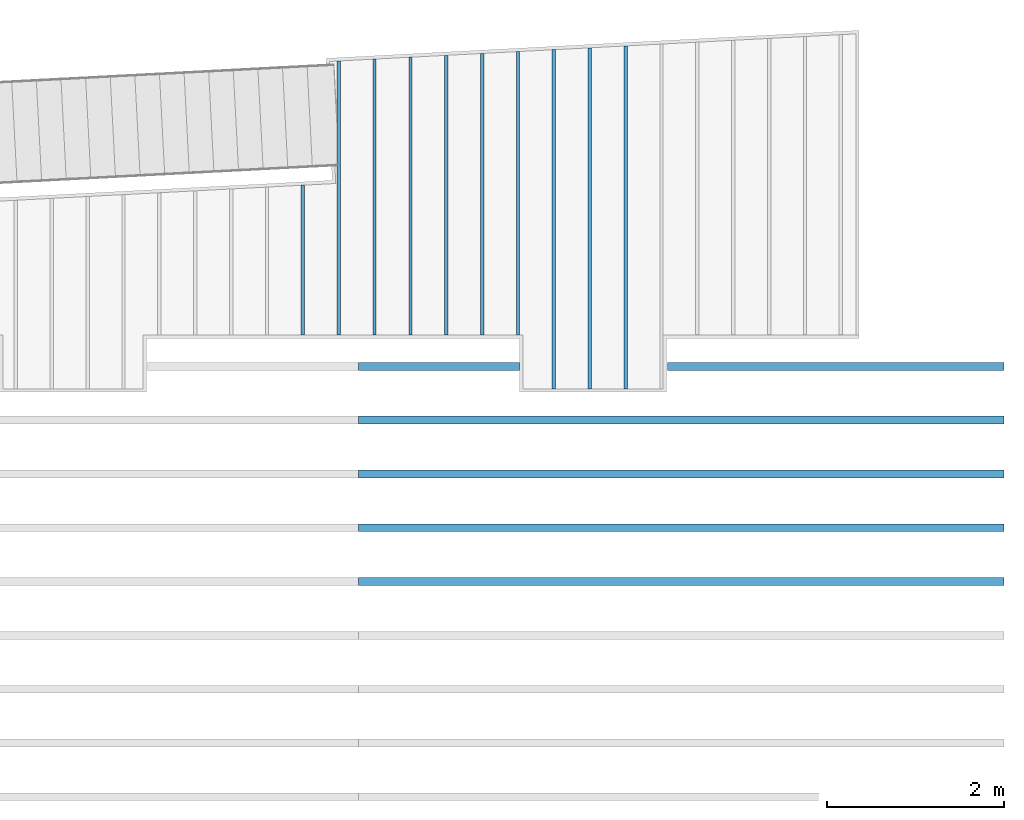
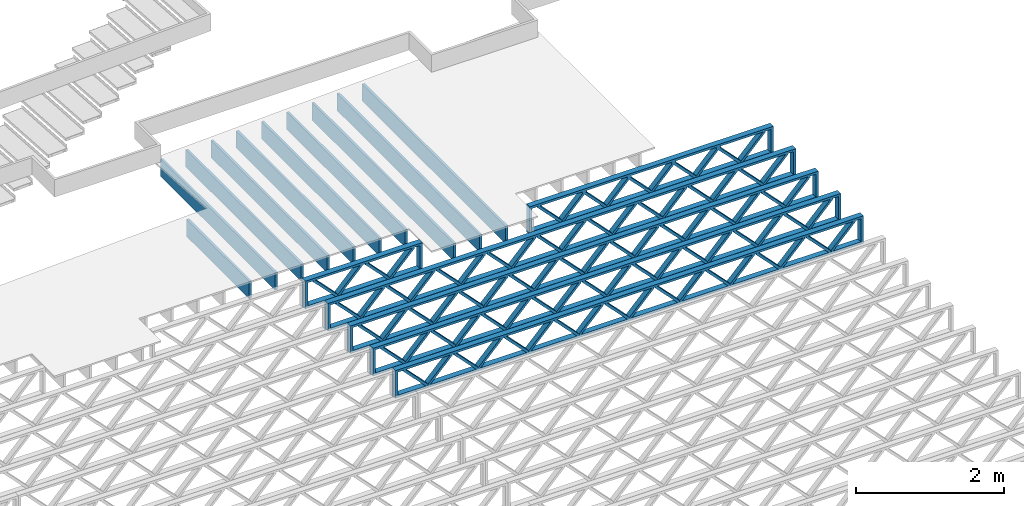
# One storey, part 12 of 23: 16 beams, 2 elements without a shape of their own.
"""IFC4 building model written with IfcOpenShell, lengths in feet."""

from ifc_helpers import new_model, entity, si_unit, converted_unit, derived_unit, direction, frame, frame_2d, origin, origin_2d_with_axis, place, context, subcontext, project, spatial, rectangle, extrude, source, transform, mapped, material, material_profile, profile_set, profile_usage, type_object, type_shapes, element, aggregate, save


model = new_model("IFC4")

# Units and contexts
model_context_1 = context("Model", 3, precision=0.0001, world=origin(), true_north=direction((6.12303176911189e-17, 1.0)))
model_context_2 = context("Model", 3, precision=0.0001, world=origin(), true_north=direction((6.12303176911189e-17, 1.0)))
body_context = subcontext(model_context_2, "Body", "Model", "MODEL_VIEW")
ifc_project = project(units=[converted_unit("LENGTHUNIT", "FOOT", entity("IfcRatioMeasure", 0.3048), si_unit("LENGTHUNIT", "METRE"), dimensions=[1, 0, 0, 0, 0, 0, 0]), converted_unit("AREAUNIT", "SQUARE FOOT", entity("IfcRatioMeasure", 0.09290304), si_unit("AREAUNIT", "SQUARE_METRE"), dimensions=[2, 0, 0, 0, 0, 0, 0]), converted_unit("VOLUMEUNIT", "CUBIC FOOT", entity("IfcRatioMeasure", 0.028316846592), si_unit("VOLUMEUNIT", "CUBIC_METRE"), dimensions=[3, 0, 0, 0, 0, 0, 0]), converted_unit("PLANEANGLEUNIT", "DEGREE", entity("IfcRatioMeasure", 0.0174532925199433), si_unit("PLANEANGLEUNIT", "RADIAN"), dimensions=[0, 0, 0, 0, 0, 0, 0]), si_unit("MASSUNIT", "GRAM", prefix="KILO"), derived_unit("MASSDENSITYUNIT", [(si_unit("MASSUNIT", "GRAM", prefix="KILO"), 1), (si_unit("LENGTHUNIT", "METRE"), -3)]), derived_unit("MOMENTOFINERTIAUNIT", [(si_unit("LENGTHUNIT", "METRE"), 4)]), si_unit("TIMEUNIT", "SECOND"), si_unit("FREQUENCYUNIT", "HERTZ"), si_unit("THERMODYNAMICTEMPERATUREUNIT", "DEGREE_CELSIUS"), derived_unit("THERMALTRANSMITTANCEUNIT", [(si_unit("MASSUNIT", "GRAM", prefix="KILO"), 1), (si_unit("THERMODYNAMICTEMPERATUREUNIT", "KELVIN"), -1), (si_unit("TIMEUNIT", "SECOND"), -3)]), derived_unit("VOLUMETRICFLOWRATEUNIT", [(si_unit("LENGTHUNIT", "METRE"), 3), (si_unit("TIMEUNIT", "SECOND"), -1)]), si_unit("ELECTRICCURRENTUNIT", "AMPERE"), si_unit("ELECTRICVOLTAGEUNIT", "VOLT"), si_unit("POWERUNIT", "WATT"), si_unit("FORCEUNIT", "NEWTON"), si_unit("ILLUMINANCEUNIT", "LUX"), si_unit("LUMINOUSFLUXUNIT", "LUMEN"), si_unit("LUMINOUSINTENSITYUNIT", "CANDELA"), derived_unit("USERDEFINED", [(si_unit("MASSUNIT", "GRAM", prefix="KILO"), -1), (si_unit("LENGTHUNIT", "METRE"), -2), (si_unit("TIMEUNIT", "SECOND"), 3), (si_unit("LUMINOUSFLUXUNIT", "LUMEN"), 1)]), derived_unit("LINEARVELOCITYUNIT", [(si_unit("LENGTHUNIT", "METRE"), 1), (si_unit("TIMEUNIT", "SECOND"), -1)]), si_unit("PRESSUREUNIT", "PASCAL"), derived_unit("USERDEFINED", [(si_unit("LENGTHUNIT", "METRE"), -2), (si_unit("MASSUNIT", "GRAM", prefix="KILO"), 1), (si_unit("TIMEUNIT", "SECOND"), -2)]), derived_unit("LINEARFORCEUNIT", [(si_unit("MASSUNIT", "GRAM", prefix="KILO"), 1), (si_unit("LENGTHUNIT", "METRE"), 1), (si_unit("TIMEUNIT", "SECOND"), -2), (si_unit("LENGTHUNIT", "METRE"), -1)]), derived_unit("PLANARFORCEUNIT", [(si_unit("MASSUNIT", "GRAM", prefix="KILO"), 1), (si_unit("LENGTHUNIT", "METRE"), 1), (si_unit("TIMEUNIT", "SECOND"), -2), (si_unit("LENGTHUNIT", "METRE"), -2)])], contexts=[model_context_1])

# Site, building, storey
site_placement = place(None, origin())
site = spatial("IfcSite", under=ifc_project, at=site_placement, CompositionType="ELEMENT")
building_placement = place(site_placement, origin())
building = spatial("IfcBuilding", under=site, at=building_placement, CompositionType="ELEMENT")
storey_placement = place(building_placement, frame((0.0, 0.0, 10.8020833333333)))
storey = spatial("IfcBuildingStorey", under=building, at=storey_placement, Name="2ND FLOOR", CompositionType="ELEMENT", Elevation=10.8020833333333)

# Assembly, beams
assembly_1_placement = place(storey_placement, origin())
assembly_1 = element("IfcElementAssembly", 1, at=assembly_1_placement, inside=storey, Name="Structural Beam System:Structural Framing System", ObjectType="Structural Beam System:Structural Framing System", AssemblyPlace="NOTDEFINED", PredefinedType="BEAM_GRID")
ifc_material_1 = material(Category="Materials")
ifc_material_profile_1 = material_profile(ifc_material_1, rectangle(XDim=0.9375, YDim=0.125000000000011, at=origin_2d_with_axis()))
ifc_profile_set_1 = profile_set([ifc_material_profile_1])
ifc_profile_usage_1 = profile_usage(ifc_profile_set_1, cardinal=8)
beam_type_1 = type_object("IfcBeamType", PredefinedType="BEAM", material=ifc_profile_set_1)
shared_shape_1 = source(origin(), body_context, "Body", "SweptSolid", [
    extrude(rectangle(XDim=0.9375, YDim=0.125000000000011, at=origin_2d_with_axis()), frame((-6.33615206190325, 0.0, 0.0), z_axis=(1.0, 0.0, 0.0), x_axis=(0.0, 0.0, -1.0)), (0.0, 0.0, 1.0), 12.6723041238065),
])
type_shapes(beam_type_1, [shared_shape_1])
beam_1_placement = place(assembly_1_placement, frame((-155.800660485462, 963.364753611221, -0.729166666666744), z_axis=(0.0, 0.0, 1.0), x_axis=(0.0, 1.0, 0.0)))
beam_1 = element("IfcBeam", 2, at=beam_1_placement, type_object=beam_type_1, material=ifc_profile_usage_1, PredefinedType="BEAM", context=body_context, shape_type="MappedRepresentation", body=[
    mapped(shared_shape_1, transform((0.0, 0.0, 0.0), scale=1.0)),
])
ifc_profile_usage_2 = profile_usage(ifc_profile_set_1, cardinal=8)
beam_type_2 = type_object("IfcBeamType", PredefinedType="BEAM", material=ifc_profile_set_1)
shared_shape_2 = source(origin(), body_context, "Body", "SweptSolid", [
    extrude(rectangle(XDim=0.9375, YDim=0.125000000000011, at=origin_2d_with_axis()), frame((-6.30121354238122, 0.0, 0.0), z_axis=(1.0, 0.0, 0.0), x_axis=(0.0, 0.0, -1.0)), (0.0, 0.0, 1.0), 12.6024270847624),
])
type_shapes(beam_type_2, [shared_shape_2])
beam_2_placement = place(assembly_1_placement, frame((-157.133993818795, 963.329815091699, -0.729166666666744), z_axis=(0.0, 0.0, 1.0), x_axis=(0.0, 1.0, 0.0)))
beam_2 = element("IfcBeam", 3, at=beam_2_placement, type_object=beam_type_2, material=ifc_profile_usage_2, PredefinedType="BEAM", context=body_context, shape_type="MappedRepresentation", body=[
    mapped(shared_shape_2, transform((0.0, 0.0, 0.0), scale=1.0)),
])
ifc_profile_usage_3 = profile_usage(ifc_profile_set_1, cardinal=8)
beam_type_3 = type_object("IfcBeamType", PredefinedType="BEAM", material=ifc_profile_set_1)
shared_shape_3 = source(origin(), body_context, "Body", "SweptSolid", [
    extrude(rectangle(XDim=0.9375, YDim=0.125000000000011, at=origin_2d_with_axis()), frame((-5.23133528385324, 0.0, 0.0), z_axis=(1.0, 0.0, 0.0), x_axis=(0.0, 0.0, -1.0)), (0.0, 0.0, 1.0), 10.4626705677065),
])
type_shapes(beam_type_3, [shared_shape_3])
beam_3_placement = place(assembly_1_placement, frame((-159.800660485462, 964.259939272139, -0.729166666666744), z_axis=(0.0, 0.0, 1.0), x_axis=(0.0, 1.0, 0.0)))
beam_3 = element("IfcBeam", 4, at=beam_3_placement, type_object=beam_type_3, material=ifc_profile_usage_3, PredefinedType="BEAM", context=body_context, shape_type="MappedRepresentation", body=[
    mapped(shared_shape_3, transform((0.0, 0.0, 0.0), scale=1.0)),
])
ifc_profile_usage_4 = profile_usage(ifc_profile_set_1, cardinal=8)
beam_type_4 = type_object("IfcBeamType", PredefinedType="BEAM", material=ifc_profile_set_1)
shared_shape_4 = source(origin(), body_context, "Body", "SweptSolid", [
    extrude(rectangle(XDim=0.9375, YDim=0.125000000000011, at=origin_2d_with_axis()), frame((-5.16145857981161, 0.0, 0.0), z_axis=(1.0, 0.0, 0.0), x_axis=(0.0, 0.0, -1.0)), (0.0, 0.0, 1.0), 10.3229171596232),
])
type_shapes(beam_type_4, [shared_shape_4])
beam_4_placement = place(assembly_1_placement, frame((-162.467327152129, 964.190061898092, -0.729166666666744), z_axis=(0.0, 0.0, 1.0), x_axis=(0.0, 1.0, 0.0)))
beam_4 = element("IfcBeam", 5, at=beam_4_placement, type_object=beam_type_4, material=ifc_profile_usage_4, PredefinedType="BEAM", context=body_context, shape_type="MappedRepresentation", body=[
    mapped(shared_shape_4, transform((0.0, 0.0, 0.0), scale=1.0)),
])
ifc_profile_usage_5 = profile_usage(ifc_profile_set_1, cardinal=8)
beam_type_5 = type_object("IfcBeamType", PredefinedType="BEAM", material=ifc_profile_set_1)
shared_shape_5 = source(origin(), body_context, "Body", "SweptSolid", [
    extrude(rectangle(XDim=0.9375, YDim=0.125000000000011, at=origin_2d_with_axis()), frame((-5.12287476158264, 0.0, 0.0), z_axis=(1.0, 0.0, 0.0), x_axis=(0.0, 0.0, -1.0)), (0.0, 0.0, 1.0), 10.1798882653351),
])
type_shapes(beam_type_5, [shared_shape_5])
beam_5_placement = place(assembly_1_placement, frame((-165.133993818795, 964.151477409859, -0.729166666666744), z_axis=(0.0, 0.0, 1.0), x_axis=(0.0, 1.0, 0.0)))
beam_5 = element("IfcBeam", 6, at=beam_5_placement, type_object=beam_type_5, material=ifc_profile_usage_5, PredefinedType="BEAM", context=body_context, shape_type="MappedRepresentation", body=[
    mapped(shared_shape_5, transform((0.0, 0.0, 0.0), scale=1.0)),
])
ifc_profile_usage_6 = profile_usage(ifc_profile_set_1, cardinal=8)
beam_type_6 = type_object("IfcBeamType", PredefinedType="BEAM", material=ifc_profile_set_1)
shared_shape_6 = source(origin(), body_context, "Body", "SweptSolid", [
    extrude(rectangle(XDim=0.9375, YDim=0.125000000000011, at=origin_2d_with_axis()), frame((-2.78269382036365, 0.0, 0.0), z_axis=(1.0, 0.0, 0.0), x_axis=(0.0, 0.0, -1.0)), (0.0, 0.0, 1.0), 5.56538764072729),
])
type_shapes(beam_type_6, [shared_shape_6])
beam_6_placement = place(assembly_1_placement, frame((-166.467327152129, 961.811296133637, -0.729166666666744), z_axis=(0.0, 0.0, 1.0), x_axis=(0.0, 1.0, 0.0)))
beam_6 = element("IfcBeam", 7, at=beam_6_placement, type_object=beam_type_6, material=ifc_profile_usage_6, PredefinedType="BEAM", context=body_context, shape_type="MappedRepresentation", body=[
    mapped(shared_shape_6, transform((0.0, 0.0, 0.0), scale=1.0)),
])

# Assembly, beam
assembly_2_placement = place(storey_placement, origin())
assembly_2 = element("IfcElementAssembly", 8, at=assembly_2_placement, inside=storey, Name="Structural Beam System:Structural Framing System", ObjectType="Structural Beam System:Structural Framing System", AssemblyPlace="NOTDEFINED", PredefinedType="BEAM_GRID")
ifc_material_2 = material(Name="WOOD TRUSS", Category="Materials")
ifc_material_profile_2 = material_profile(ifc_material_2, rectangle(XDim=1.73473973950632, YDim=0.125, at=frame_2d((-1.11022302462516e-16, 8.32667268468867e-17), x_axis=(1.0, 0.0))))
ifc_material_profile_3 = material_profile(ifc_material_2, rectangle(XDim=1.73473973950633, YDim=0.125, at=frame_2d((-1.11022302462516e-16, 8.32667268468867e-17), x_axis=(1.0, 0.0))))
ifc_material_profile_4 = material_profile(ifc_material_2, rectangle(XDim=1.73473973950632, YDim=0.125, at=frame_2d((-5.55111512312578e-17, 1.38777878078145e-16), x_axis=(1.0, 0.0))))
ifc_material_profile_5 = material_profile(ifc_material_2, rectangle(XDim=1.73473973950633, YDim=0.125, at=frame_2d((-1.11022302462516e-16, 8.32667268468867e-17), x_axis=(1.0, 0.0))))
ifc_material_profile_6 = material_profile(ifc_material_2, rectangle(XDim=1.73473973950632, YDim=0.125, at=frame_2d((-1.11022302462516e-16, 8.32667268468867e-17), x_axis=(1.0, 0.0))))
ifc_material_profile_7 = material_profile(ifc_material_2, rectangle(XDim=1.73473973950633, YDim=0.125, at=frame_2d((-2.77555756156289e-16, 3.05311331771918e-16), x_axis=(1.0, 0.0))))
ifc_material_profile_8 = material_profile(ifc_material_2, rectangle(XDim=1.73473973950632, YDim=0.124999999999999, at=frame_2d((-3.88578058618805e-16, -2.4980018054066e-16), x_axis=(1.0, 0.0))))
ifc_material_profile_9 = material_profile(ifc_material_2, rectangle(XDim=1.73473973950633, YDim=0.125, at=frame_2d((2.77555756156289e-16, -3.05311331771918e-16), x_axis=(1.0, 0.0))))
ifc_material_profile_10 = material_profile(ifc_material_2, rectangle(XDim=1.73473973950632, YDim=0.124999999999999, at=frame_2d((-1.11022302462516e-16, 8.32667268468867e-17), x_axis=(1.0, 0.0))))
ifc_material_profile_11 = material_profile(ifc_material_2, rectangle(XDim=1.73473973950633, YDim=0.125, at=origin_2d_with_axis()))
ifc_material_profile_12 = material_profile(ifc_material_2, rectangle(XDim=0.124999999999982, YDim=0.291666666666668, at=origin_2d_with_axis()))
ifc_material_profile_13 = material_profile(ifc_material_2, rectangle(XDim=0.124999999999932, YDim=0.291666666666664, at=origin_2d_with_axis()))
ifc_material_profile_14 = material_profile(ifc_material_2, rectangle(XDim=1.25000000000002, YDim=0.29166666666667, at=origin_2d_with_axis()))
ifc_material_profile_15 = material_profile(ifc_material_2, rectangle(XDim=1.25000000000004, YDim=0.291666666666667, at=origin_2d_with_axis()))
ifc_profile_set_2 = profile_set([ifc_material_profile_2, ifc_material_profile_3, ifc_material_profile_4, ifc_material_profile_5, ifc_material_profile_6, ifc_material_profile_7, ifc_material_profile_8, ifc_material_profile_9, ifc_material_profile_10, ifc_material_profile_11, ifc_material_profile_12, ifc_material_profile_13, ifc_material_profile_14, ifc_material_profile_15])
ifc_profile_usage_7 = profile_usage(ifc_profile_set_2, cardinal=8)
beam_type_7 = type_object("IfcBeamType", PredefinedType="BEAM", material=ifc_profile_set_2)
shared_shape_7 = source(origin(), body_context, "Body", "SweptSolid", [
    extrude(rectangle(XDim=1.73473973950632, YDim=0.125, at=frame_2d((-1.11022302462516e-16, 8.32667268468867e-17), x_axis=(1.0, 0.0))), frame((2.91681155651982, -0.145833333333334, 0.0), z_axis=(0.0, 1.0, 0.0), x_axis=(0.693383046997606, 0.0, 0.720569184836762)), (0.0, 0.0, 1.0), 0.291666666666667),
    extrude(rectangle(XDim=1.73473973950633, YDim=0.125, at=frame_2d((-1.11022302462516e-16, 8.32667268468867e-17), x_axis=(1.0, 0.0))), frame((1.66652568284655, -0.145833333333334, 0.0), z_axis=(0.0, 1.0, 0.0), x_axis=(0.69338304699761, 0.0, -0.720569184836758)), (0.0, 0.0, 1.0), 0.291666666666667),
    extrude(rectangle(XDim=1.73473973950632, YDim=0.125, at=frame_2d((-5.55111512312578e-17, 1.38777878078145e-16), x_axis=(1.0, 0.0))), frame((0.625142936836964, -0.145833333333334, 0.0), z_axis=(0.0, 1.0, 0.0), x_axis=(0.693383046997606, 0.0, 0.720569184836762)), (0.0, 0.0, 1.0), 0.291666666666667),
    extrude(rectangle(XDim=1.73473973950633, YDim=0.125, at=frame_2d((-1.11022302462516e-16, 8.32667268468867e-17), x_axis=(1.0, 0.0))), frame((-0.625142936836307, -0.145833333333334, 0.0), z_axis=(0.0, 1.0, 0.0), x_axis=(0.69338304699761, 0.0, -0.720569184836758)), (0.0, 0.0, 1.0), 0.291666666666667),
    extrude(rectangle(XDim=1.73473973950632, YDim=0.125, at=frame_2d((-1.11022302462516e-16, 8.32667268468867e-17), x_axis=(1.0, 0.0))), frame((-1.66652568284589, -0.145833333333334, 0.0), z_axis=(0.0, 1.0, 0.0), x_axis=(0.693383046997606, 0.0, 0.720569184836762)), (0.0, 0.0, 1.0), 0.291666666666667),
    extrude(rectangle(XDim=1.73473973950633, YDim=0.125, at=frame_2d((-2.77555756156289e-16, 3.05311331771918e-16), x_axis=(1.0, 0.0))), frame((-2.91681155651916, -0.145833333333334, 0.0), z_axis=(0.0, 1.0, 0.0), x_axis=(0.69338304699761, 0.0, -0.720569184836758)), (0.0, 0.0, 1.0), 0.291666666666667),
    extrude(rectangle(XDim=1.73473973950632, YDim=0.124999999999999, at=frame_2d((-3.88578058618805e-16, -2.4980018054066e-16), x_axis=(1.0, 0.0))), frame((5.20848017620267, -0.145833333333334, 0.0), z_axis=(0.0, 1.0, 0.0), x_axis=(0.693383046997607, 0.0, 0.720569184836761)), (0.0, 0.0, 1.0), 0.291666666666666),
    extrude(rectangle(XDim=1.73473973950633, YDim=0.125, at=frame_2d((2.77555756156289e-16, -3.05311331771918e-16), x_axis=(1.0, 0.0))), frame((3.9581943025294, -0.145833333333334, 0.0), z_axis=(0.0, 1.0, 0.0), x_axis=(0.69338304699761, 0.0, -0.720569184836758)), (0.0, 0.0, 1.0), 0.291666666666666),
    extrude(rectangle(XDim=1.73473973950632, YDim=0.124999999999999, at=frame_2d((-1.11022302462516e-16, 8.32667268468867e-17), x_axis=(1.0, 0.0))), frame((-3.95819430252874, -0.145833333333334, 0.0), z_axis=(0.0, 1.0, 0.0), x_axis=(0.693383046997606, 0.0, 0.720569184836762)), (0.0, 0.0, 1.0), 0.291666666666667),
    extrude(rectangle(XDim=1.73473973950633, YDim=0.125, at=origin_2d_with_axis()), frame((-5.20848017620202, -0.145833333333334, 0.0), z_axis=(0.0, 1.0, 0.0), x_axis=(0.69338304699761, 0.0, -0.720569184836758)), (0.0, 0.0, 1.0), 0.291666666666666),
    extrude(rectangle(XDim=0.124999999999982, YDim=0.291666666666668, at=origin_2d_with_axis()), frame((-6.25000390603229, 0.0, 0.687500000000054), z_axis=(1.0, 0.0, 0.0), x_axis=(0.0, 0.0, -1.0)), (0.0, 0.0, 1.0), 12.5000078120646),
    extrude(rectangle(XDim=0.124999999999932, YDim=0.291666666666664, at=origin_2d_with_axis()), frame((-6.25000390603208, 0.0, -0.687499999999984), z_axis=(1.0, 0.0, 0.0), x_axis=(0.0, 0.0, -1.0)), (0.0, 0.0, 1.0), 12.5000078120644),
    extrude(rectangle(XDim=1.25000000000002, YDim=0.29166666666667, at=origin_2d_with_axis()), frame((6.12500390603227, 0.0, 0.0), z_axis=(1.0, 0.0, 0.0), x_axis=(0.0, 0.0, -1.0)), (0.0, 0.0, 1.0), 0.12500000000002),
    extrude(rectangle(XDim=1.25000000000004, YDim=0.291666666666667, at=origin_2d_with_axis()), frame((-6.25000390603229, 0.0, 0.0), z_axis=(1.0, 0.0, 0.0), x_axis=(0.0, 0.0, -1.0)), (0.0, 0.0, 1.0), 0.125000000000023),
])
type_shapes(beam_type_7, [shared_shape_7])
beam_7_placement = place(assembly_2_placement, frame((-146.654823274369, 957.861934882651, -0.947916666657857), z_axis=(0.0, 0.0, 1.0), x_axis=(-1.0, 0.0, 0.0)))
beam_7 = element("IfcBeam", 9, at=beam_7_placement, type_object=beam_type_7, material=ifc_profile_usage_7, PredefinedType="BEAM", context=body_context, shape_type="MappedRepresentation", body=[
    mapped(shared_shape_7, transform((0.0, 0.0, 0.0), scale=1.0)),
])

# Beam
ifc_profile_usage_8 = profile_usage(ifc_profile_set_1, cardinal=8)
beam_type_8 = type_object("IfcBeamType", PredefinedType="BEAM", material=ifc_profile_set_1)
shared_shape_8 = source(origin(), body_context, "Body", "SweptSolid", [
    extrude(rectangle(XDim=0.9375, YDim=0.125000000000011, at=origin_2d_with_axis()), frame((-5.12652022779071, 0.0, 0.0), z_axis=(1.0, 0.0, 0.0), x_axis=(0.0, 0.0, -1.0)), (0.0, 0.0, 1.0), 10.2530404555814),
])
type_shapes(beam_type_8, [shared_shape_8])
beam_8_placement = place(assembly_1_placement, frame((-163.800660485462, 964.155123211069, -0.729166666666744), z_axis=(0.0, 0.0, 1.0), x_axis=(0.0, 1.0, 0.0)))
beam_8 = element("IfcBeam", 10, at=beam_8_placement, type_object=beam_type_8, material=ifc_profile_usage_8, PredefinedType="BEAM", context=body_context, shape_type="MappedRepresentation", body=[
    mapped(shared_shape_8, transform((0.0, 0.0, 0.0), scale=1.0)),
])

ifc_profile_usage_9 = profile_usage(ifc_profile_set_1, cardinal=8)
beam_type_9 = type_object("IfcBeamType", PredefinedType="BEAM", material=ifc_profile_set_1)
shared_shape_9 = source(origin(), body_context, "Body", "SweptSolid", [
    extrude(rectangle(XDim=0.9375, YDim=0.125000000000011, at=origin_2d_with_axis()), frame((-5.19639693183245, 0.0, 0.0), z_axis=(1.0, 0.0, 0.0), x_axis=(0.0, 0.0, -1.0)), (0.0, 0.0, 1.0), 10.3927938636649),
])
type_shapes(beam_type_9, [shared_shape_9])
beam_9_placement = place(assembly_1_placement, frame((-161.133993818795, 964.225000585116, -0.729166666666744), z_axis=(0.0, 0.0, 1.0), x_axis=(0.0, 1.0, 0.0)))
beam_9 = element("IfcBeam", 11, at=beam_9_placement, type_object=beam_type_9, material=ifc_profile_usage_9, PredefinedType="BEAM", context=body_context, shape_type="MappedRepresentation", body=[
    mapped(shared_shape_9, transform((0.0, 0.0, 0.0), scale=1.0)),
])

ifc_profile_usage_10 = profile_usage(ifc_profile_set_1, cardinal=8)
beam_type_10 = type_object("IfcBeamType", PredefinedType="BEAM", material=ifc_profile_set_1)
shared_shape_10 = source(origin(), body_context, "Body", "SweptSolid", [
    extrude(rectangle(XDim=0.9375, YDim=0.125000000000011, at=origin_2d_with_axis()), frame((-5.26627363587414, 0.0, 0.0), z_axis=(1.0, 0.0, 0.0), x_axis=(0.0, 0.0, -1.0)), (0.0, 0.0, 1.0), 10.5325472717483),
])
type_shapes(beam_type_10, [shared_shape_10])
beam_10_placement = place(assembly_1_placement, frame((-158.467327152129, 964.294877959162, -0.729166666666744), z_axis=(0.0, 0.0, 1.0), x_axis=(0.0, 1.0, 0.0)))
beam_10 = element("IfcBeam", 12, at=beam_10_placement, type_object=beam_type_10, material=ifc_profile_usage_10, PredefinedType="BEAM", context=body_context, shape_type="MappedRepresentation", body=[
    mapped(shared_shape_10, transform((0.0, 0.0, 0.0), scale=1.0)),
])

ifc_profile_usage_11 = profile_usage(ifc_profile_set_1, cardinal=8)
beam_type_11 = type_object("IfcBeamType", PredefinedType="BEAM", material=ifc_profile_set_1)
shared_shape_11 = source(origin(), body_context, "Body", "SweptSolid", [
    extrude(rectangle(XDim=0.9375, YDim=0.125000000000011, at=origin_2d_with_axis()), frame((-6.37109058142528, 0.0, 0.0), z_axis=(1.0, 0.0, 0.0), x_axis=(0.0, 0.0, -1.0)), (0.0, 0.0, 1.0), 12.7421811628506),
])
type_shapes(beam_type_11, [shared_shape_11])
beam_11_placement = place(assembly_1_placement, frame((-154.467327152129, 963.399692130743, -0.729166666666744), z_axis=(0.0, 0.0, 1.0), x_axis=(0.0, 1.0, 0.0)))
beam_11 = element("IfcBeam", 13, at=beam_11_placement, type_object=beam_type_11, material=ifc_profile_usage_11, PredefinedType="BEAM", context=body_context, shape_type="MappedRepresentation", body=[
    mapped(shared_shape_11, transform((0.0, 0.0, 0.0), scale=1.0)),
])

aggregate(assembly_1, [beam_1, beam_2, beam_3, beam_4, beam_5, beam_6, beam_8, beam_9, beam_10, beam_11])

ifc_profile_usage_12 = profile_usage(ifc_profile_set_2, cardinal=8)
beam_type_12 = type_object("IfcBeamType", PredefinedType="BEAM", material=ifc_profile_set_2)
shared_shape_12 = source(origin(), body_context, "Body", "SweptSolid", [
    extrude(rectangle(XDim=1.73473973950632, YDim=0.124999999999999, at=frame_2d((5.55111512312578e-16, 7.21644966006352e-16), x_axis=(1.0, 0.0))), frame((8.37514585578398, -0.145833333333334, 0.0), z_axis=(0.0, 1.0, 0.0), x_axis=(0.693383046997606, 0.0, 0.720569184836762)), (0.0, 0.0, 1.0), 0.291666666666667),
    extrude(rectangle(XDim=1.73473973950633, YDim=0.125, at=origin_2d_with_axis()), frame((7.12485998211071, -0.145833333333334, 0.0), z_axis=(0.0, 1.0, 0.0), x_axis=(0.69338304699761, 0.0, -0.720569184836758)), (0.0, 0.0, 1.0), 0.291666666666666),
    extrude(rectangle(XDim=1.73473973950632, YDim=0.124999999999999, at=frame_2d((-1.11022302462516e-16, 8.32667268468867e-17), x_axis=(1.0, 0.0))), frame((5.79181154946831, -0.145833333333334, 0.0), z_axis=(0.0, 1.0, 0.0), x_axis=(0.693383046997606, 0.0, 0.720569184836762)), (0.0, 0.0, 1.0), 0.291666666666667),
    extrude(rectangle(XDim=1.73473973950633, YDim=0.125, at=origin_2d_with_axis()), frame((4.54152567579504, -0.145833333333334, 0.0), z_axis=(0.0, 1.0, 0.0), x_axis=(0.69338304699761, 0.0, -0.720569184836758)), (0.0, 0.0, 1.0), 0.291666666666666),
    extrude(rectangle(XDim=1.73473973950632, YDim=0.125, at=frame_2d((2.22044604925031e-16, 3.88578058618805e-16), x_axis=(1.0, 0.0))), frame((3.20847724315264, -0.145833333333334, 0.0), z_axis=(0.0, 1.0, 0.0), x_axis=(0.693383046997606, 0.0, 0.720569184836762)), (0.0, 0.0, 1.0), 0.291666666666667),
    extrude(rectangle(XDim=1.73473973950633, YDim=0.125, at=frame_2d((-1.11022302462516e-16, 8.32667268468867e-17), x_axis=(1.0, 0.0))), frame((1.95819136947937, -0.145833333333334, 0.0), z_axis=(0.0, 1.0, 0.0), x_axis=(0.69338304699761, 0.0, -0.720569184836758)), (0.0, 0.0, 1.0), 0.291666666666667),
    extrude(rectangle(XDim=1.73473973950632, YDim=0.125, at=frame_2d((-5.55111512312578e-17, 1.38777878078145e-16), x_axis=(1.0, 0.0))), frame((0.625142936836964, -0.145833333333334, 0.0), z_axis=(0.0, 1.0, 0.0), x_axis=(0.693383046997606, 0.0, 0.720569184836762)), (0.0, 0.0, 1.0), 0.291666666666667),
    extrude(rectangle(XDim=1.73473973950633, YDim=0.125, at=frame_2d((-1.11022302462516e-16, 8.32667268468867e-17), x_axis=(1.0, 0.0))), frame((-0.625142936836306, -0.145833333333334, 0.0), z_axis=(0.0, 1.0, 0.0), x_axis=(0.69338304699761, 0.0, -0.720569184836758)), (0.0, 0.0, 1.0), 0.291666666666667),
    extrude(rectangle(XDim=1.73473973950632, YDim=0.125, at=frame_2d((-1.11022302462516e-16, 8.32667268468867e-17), x_axis=(1.0, 0.0))), frame((-1.95819136947871, -0.145833333333334, 0.0), z_axis=(0.0, 1.0, 0.0), x_axis=(0.693383046997606, 0.0, 0.720569184836762)), (0.0, 0.0, 1.0), 0.291666666666667),
    extrude(rectangle(XDim=1.73473973950633, YDim=0.125, at=origin_2d_with_axis()), frame((-3.20847724315198, -0.145833333333334, 0.0), z_axis=(0.0, 1.0, 0.0), x_axis=(0.69338304699761, 0.0, -0.720569184836758)), (0.0, 0.0, 1.0), 0.291666666666667),
    extrude(rectangle(XDim=1.73473973950632, YDim=0.124999999999999, at=frame_2d((-1.11022302462516e-16, 8.32667268468867e-17), x_axis=(1.0, 0.0))), frame((-4.54152567579438, -0.145833333333334, 0.0), z_axis=(0.0, 1.0, 0.0), x_axis=(0.693383046997606, 0.0, 0.720569184836762)), (0.0, 0.0, 1.0), 0.291666666666667),
    extrude(rectangle(XDim=1.73473973950633, YDim=0.125, at=origin_2d_with_axis()), frame((-5.79181154946765, -0.145833333333334, 0.0), z_axis=(0.0, 1.0, 0.0), x_axis=(0.69338304699761, 0.0, -0.720569184836758)), (0.0, 0.0, 1.0), 0.291666666666666),
    extrude(rectangle(XDim=1.73473973950632, YDim=0.124999999999999, at=frame_2d((-1.11022302462516e-16, 8.32667268468867e-17), x_axis=(1.0, 0.0))), frame((-7.12485998211005, -0.145833333333334, 0.0), z_axis=(0.0, 1.0, 0.0), x_axis=(0.693383046997606, 0.0, 0.720569184836762)), (0.0, 0.0, 1.0), 0.291666666666667),
    extrude(rectangle(XDim=1.73473973950633, YDim=0.125, at=frame_2d((-2.77555756156289e-16, 3.05311331771918e-16), x_axis=(1.0, 0.0))), frame((-8.37514585578332, -0.145833333333334, 0.0), z_axis=(0.0, 1.0, 0.0), x_axis=(0.69338304699761, 0.0, -0.720569184836758)), (0.0, 0.0, 1.0), 0.291666666666666),
    extrude(rectangle(XDim=1.73473973950632, YDim=0.125, at=frame_2d((-7.21644966006352e-16, -5.55111512312578e-16), x_axis=(1.0, 0.0))), frame((10.9584801620997, -0.145833333333334, 0.0), z_axis=(0.0, 1.0, 0.0), x_axis=(0.693383046997606, 0.0, 0.720569184836762)), (0.0, 0.0, 1.0), 0.291666666666667),
    extrude(rectangle(XDim=1.73473973950633, YDim=0.125, at=origin_2d_with_axis()), frame((9.70819428842638, -0.145833333333334, 0.0), z_axis=(0.0, 1.0, 0.0), x_axis=(0.69338304699761, 0.0, -0.720569184836758)), (0.0, 0.0, 1.0), 0.291666666666666),
    extrude(rectangle(XDim=1.73473973950632, YDim=0.125, at=frame_2d((-5.55111512312578e-17, 8.32667268468867e-17), x_axis=(1.0, 0.0))), frame((-9.70819428842572, -0.145833333333334, 0.0), z_axis=(0.0, 1.0, 0.0), x_axis=(0.693383046997606, 0.0, 0.720569184836762)), (0.0, 0.0, 1.0), 0.291666666666667),
    extrude(rectangle(XDim=1.73473973950633, YDim=0.125, at=origin_2d_with_axis()), frame((-10.958480162099, -0.145833333333334, 0.0), z_axis=(0.0, 1.0, 0.0), x_axis=(0.69338304699761, 0.0, -0.720569184836758)), (0.0, 0.0, 1.0), 0.291666666666666),
    extrude(rectangle(XDim=0.124999999999982, YDim=0.291666666666668, at=origin_2d_with_axis()), frame((-12.0000038919293, 0.0, 0.687500000000054), z_axis=(1.0, 0.0, 0.0), x_axis=(0.0, 0.0, -1.0)), (0.0, 0.0, 1.0), 24.0000077838585),
    extrude(rectangle(XDim=0.124999999999932, YDim=0.291666666666664, at=origin_2d_with_axis()), frame((-12.0000038919291, 0.0, -0.687499999999984), z_axis=(1.0, 0.0, 0.0), x_axis=(0.0, 0.0, -1.0)), (0.0, 0.0, 1.0), 24.0000077838583),
    extrude(rectangle(XDim=1.25000000000002, YDim=0.29166666666667, at=origin_2d_with_axis()), frame((11.8750038919292, 0.0, 0.0), z_axis=(1.0, 0.0, 0.0), x_axis=(0.0, 0.0, -1.0)), (0.0, 0.0, 1.0), 0.12500000000002),
    extrude(rectangle(XDim=1.25000000000004, YDim=0.291666666666667, at=origin_2d_with_axis()), frame((-12.0000038919293, 0.0, 0.0), z_axis=(1.0, 0.0, 0.0), x_axis=(0.0, 0.0, -1.0)), (0.0, 0.0, 1.0), 0.125000000000023),
])
type_shapes(beam_type_12, [shared_shape_12])
beam_12_placement = place(assembly_2_placement, frame((-152.404823260266, 951.861934882651, -0.947916666657859), z_axis=(0.0, 0.0, 1.0), x_axis=(-1.0, 0.0, 0.0)))
beam_12 = element("IfcBeam", 14, at=beam_12_placement, type_object=beam_type_12, material=ifc_profile_usage_12, PredefinedType="BEAM", context=body_context, shape_type="MappedRepresentation", body=[
    mapped(shared_shape_12, transform((0.0, 0.0, 0.0), scale=1.0)),
])

ifc_profile_usage_13 = profile_usage(ifc_profile_set_2, cardinal=8)
beam_13_placement = place(assembly_2_placement, frame((-152.404823260266, 953.861934882651, -0.947916666657859), z_axis=(0.0, 0.0, 1.0), x_axis=(-1.0, 0.0, 0.0)))
beam_13 = element("IfcBeam", 15, at=beam_13_placement, type_object=beam_type_12, material=ifc_profile_usage_13, PredefinedType="BEAM", context=body_context, shape_type="MappedRepresentation", body=[
    mapped(shared_shape_12, transform((0.0, 0.0, 0.0), scale=1.0)),
])

ifc_profile_usage_14 = profile_usage(ifc_profile_set_2, cardinal=8)
beam_14_placement = place(assembly_2_placement, frame((-152.404823260266, 955.861934882651, -0.947916666657859), z_axis=(0.0, 0.0, 1.0), x_axis=(-1.0, 0.0, 0.0)))
beam_14 = element("IfcBeam", 16, at=beam_14_placement, type_object=beam_type_12, material=ifc_profile_usage_14, PredefinedType="BEAM", context=body_context, shape_type="MappedRepresentation", body=[
    mapped(shared_shape_12, transform((0.0, 0.0, 0.0), scale=1.0)),
])

ifc_profile_usage_15 = profile_usage(ifc_profile_set_2, cardinal=8)
beam_15_placement = place(assembly_2_placement, frame((-152.404823260266, 949.861934882651, -0.947916666657859), z_axis=(0.0, 0.0, 1.0), x_axis=(-1.0, 0.0, 0.0)))
beam_15 = element("IfcBeam", 17, at=beam_15_placement, type_object=beam_type_12, material=ifc_profile_usage_15, PredefinedType="BEAM", context=body_context, shape_type="MappedRepresentation", body=[
    mapped(shared_shape_12, transform((0.0, 0.0, 0.0), scale=1.0)),
])

ifc_profile_usage_16 = profile_usage(ifc_profile_set_2, cardinal=8)
beam_type_13 = type_object("IfcBeamType", PredefinedType="BEAM", material=ifc_profile_set_2)
shared_shape_13 = source(origin(), body_context, "Body", "SweptSolid", [
    extrude(rectangle(XDim=1.73473973950632, YDim=0.125, at=frame_2d((0.0, 1.66533453693773e-16), x_axis=(1.0, 0.0))), frame((1.95847576769603, -0.145833333333334, 0.0), z_axis=(0.0, 1.0, 0.0), x_axis=(0.693383046997606, 0.0, 0.720569184836762)), (0.0, 0.0, 1.0), 0.291666666666667),
    extrude(rectangle(XDim=1.73473973950633, YDim=0.125, at=frame_2d((-5.55111512312578e-17, 8.32667268468867e-17), x_axis=(1.0, 0.0))), frame((0.708189894022761, -0.145833333333334, 0.0), z_axis=(0.0, 1.0, 0.0), x_axis=(0.69338304699761, 0.0, -0.720569184836758)), (0.0, 0.0, 1.0), 0.291666666666667),
    extrude(rectangle(XDim=1.73473973950632, YDim=0.125, at=frame_2d((0.0, 1.66533453693773e-16), x_axis=(1.0, 0.0))), frame((-0.708189894022106, -0.145833333333334, 0.0), z_axis=(0.0, 1.0, 0.0), x_axis=(0.693383046997606, 0.0, 0.720569184836762)), (0.0, 0.0, 1.0), 0.291666666666667),
    extrude(rectangle(XDim=1.73473973950633, YDim=0.125, at=frame_2d((-2.22044604925031e-16, 2.22044604925031e-16), x_axis=(1.0, 0.0))), frame((-1.95847576769538, -0.145833333333334, 0.0), z_axis=(0.0, 1.0, 0.0), x_axis=(0.69338304699761, 0.0, -0.720569184836758)), (0.0, 0.0, 1.0), 0.291666666666666),
    extrude(rectangle(XDim=0.124999999999982, YDim=0.291666666666668, at=origin_2d_with_axis()), frame((-2.99999949752565, 0.0, 0.687500000000054), z_axis=(1.0, 0.0, 0.0), x_axis=(0.0, 0.0, -1.0)), (0.0, 0.0, 1.0), 5.9999989950513),
    extrude(rectangle(XDim=0.124999999999932, YDim=0.291666666666664, at=origin_2d_with_axis()), frame((-2.99999949752544, 0.0, -0.687499999999984), z_axis=(1.0, 0.0, 0.0), x_axis=(0.0, 0.0, -1.0)), (0.0, 0.0, 1.0), 5.99999899505109),
    extrude(rectangle(XDim=1.25000000000002, YDim=0.29166666666667, at=origin_2d_with_axis()), frame((2.87499949752563, 0.0, 0.0), z_axis=(1.0, 0.0, 0.0), x_axis=(0.0, 0.0, -1.0)), (0.0, 0.0, 1.0), 0.12500000000002),
    extrude(rectangle(XDim=1.25000000000004, YDim=0.291666666666667, at=origin_2d_with_axis()), frame((-2.99999949752565, 0.0, 0.0), z_axis=(1.0, 0.0, 0.0), x_axis=(0.0, 0.0, -1.0)), (0.0, 0.0, 1.0), 0.125000000000023),
])
type_shapes(beam_type_13, [shared_shape_13])
beam_16_placement = place(assembly_2_placement, frame((-161.40482765467, 957.861934882651, -0.947916666657848), z_axis=(0.0, 0.0, 1.0), x_axis=(-1.0, 0.0, 0.0)))
beam_16 = element("IfcBeam", 18, at=beam_16_placement, type_object=beam_type_13, material=ifc_profile_usage_16, PredefinedType="BEAM", context=body_context, shape_type="MappedRepresentation", body=[
    mapped(shared_shape_13, transform((0.0, 0.0, 0.0), scale=1.0)),
])

aggregate(assembly_2, [beam_7, beam_12, beam_13, beam_14, beam_15, beam_16])

save(model, "model.ifc")
